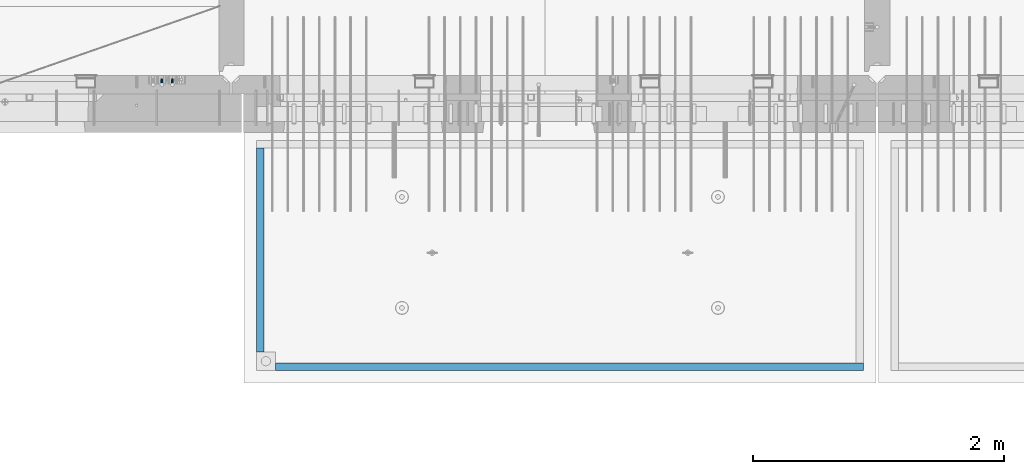
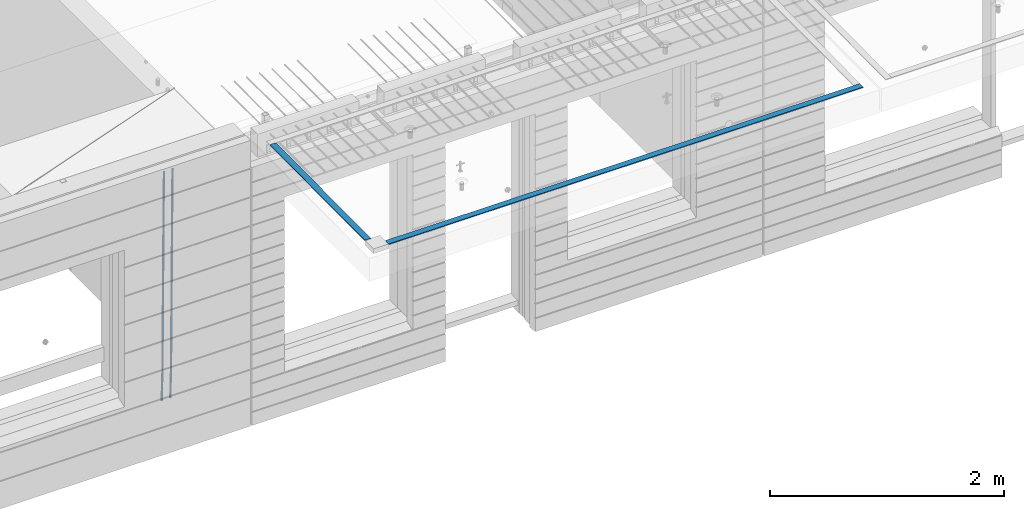
# One storey, part 90 of 341: 4 beams, 2 elements without a shape of their own.
"""IFC2X3 building model written with IfcOpenShell, lengths in millimetres."""

from ifc_helpers import new_model, si_unit, frame, origin_with_axes, place, context, subcontext, project, spatial, faceted_brep, material, type_object, element, aggregate, save


model = new_model("IFC2X3")

# Units and contexts
model_context = context("Model", 3, precision=1e-05, world=origin_with_axes())
body_context = subcontext(model_context, "Body", "Model", "MODEL_VIEW")
ifc_project = project(units=[si_unit("LENGTHUNIT", "METRE", prefix="MILLI"), si_unit("AREAUNIT", "SQUARE_METRE"), si_unit("VOLUMEUNIT", "CUBIC_METRE"), si_unit("MASSUNIT", "GRAM", prefix="KILO"), si_unit("TIMEUNIT", "SECOND"), si_unit("PLANEANGLEUNIT", "RADIAN"), si_unit("SOLIDANGLEUNIT", "STERADIAN"), si_unit("THERMODYNAMICTEMPERATUREUNIT", "DEGREE_CELSIUS"), si_unit("LUMINOUSINTENSITYUNIT", "LUMEN")], contexts=[model_context])

# Site, building, storey
site_placement = place(None, origin_with_axes())
site = spatial("IfcSite", under=ifc_project, at=site_placement, CompositionType="ELEMENT")
building_placement = place(site_placement, origin_with_axes())
building = spatial("IfcBuilding", under=site, at=building_placement, CompositionType="ELEMENT")
storey_placement = place(building_placement, origin_with_axes())
storey = spatial("IfcBuildingStorey", under=building, at=storey_placement, Name="5", CompositionType="ELEMENT", Elevation=0.0)

# Assembly, beams
assembly_1_placement = place(storey_placement, origin_with_axes())
assembly_1 = element("IfcElementAssembly", 1, at=assembly_1_placement, inside=storey, AssemblyPlace="NOTDEFINED", PredefinedType="REINFORCEMENT_UNIT")
ifc_material_1 = material()
beam_type_1 = type_object("IfcBeamType", Name="D20", PredefinedType="NOTDEFINED")
beam_1_placement = place(assembly_1_placement, frame((16189.9999999961, 7965.00000227913, 93990.0), z_axis=(0.00020576299992186, -0.999642804629538, -0.0267249099901004), x_axis=(-4.30000201928125e-08, -0.0267249099948059, 0.999642825806181)))
beam_1 = element("IfcBeam", 2, at=beam_1_placement, type_object=beam_type_1, material=ifc_material_1, Name="JM20", ObjectType="D20", context=body_context, shape_type="Brep", body=[
    faceted_brep([(0.0, -10.0, 0.0), (-4.19531716033816e-08, -7.07106781186667, -7.07106781187031), (60.4266690400545, -7.0710677960451, -7.07106780570757), (60.4266690441291, -9.99999998418934, 6.15546014159918e-09), (0.0, 0.0, -10.0), (60.426669036824, 1.58106558956206e-08, -9.99999999384454), (4.196772351861e-08, 7.07106781186303, -7.07106781186667), (60.4266690363438, 7.07106782768096, -7.07106780570757), (0.0, 10.0, 0.0), (60.4266690388904, 10.0000000158179, 6.15182216279209e-09), (4.196772351861e-08, 7.07106781185939, 7.07106781185939), (60.4266690429649, 7.07106782768096, 7.07106781802577), (0.0, 0.0, 10.0), (60.4266690461809, 1.58179318532348e-08, 10.0000000061555), (-4.19531716033816e-08, -7.07106781187031, 7.07106781185939), (60.4266690466611, -7.07106779605238, 7.07106781802213), (61.0378400410118, -7.07106779588503, -7.07106780564936), (60.991799419251, -9.99999998403655, 6.21366780251265e-09), (61.0569027789461, 1.5985278878361e-08, -9.99999999378269), (61.0378209396877, 7.07106782784831, -7.07106780564936), (60.9917724058905, 10.0000000159635, 6.21366780251265e-09), (60.9457317841297, 7.07106782781193, 7.0710678180767), (60.9266690461809, 1.59488990902901e-08, 10.0000000062028), (60.9457508854539, -7.07106779591413, 7.0710678180767), (61.6489592143771, -7.07106614513759, -7.06310863441468), (61.5568818710308, -9.9999984576425, 0.00735959856683621), (61.6870830769039, 1.71821739058942e-06, -9.99179257185824), (61.6489210170112, 7.07106947854481, -7.06310888312146), (61.556827851804, 10.0000015422847, 0.00735924683976918), (61.4647505084577, 7.07106922979438, 7.07782747982128), (61.4266266459163, 1.36643211590126e-06, 10.0065114172685), (61.464788705809, -7.07106639389531, 7.07782772852806), (176.543135720174, -7.07075579406956, -5.56673531796696), (176.451058376813, -9.99968810657447, 1.50373291501455), (176.581259582701, 0.000312069292704109, -8.49541925541052), (176.543097522794, 7.07137982961285, -5.56673556667374), (176.451004357587, 10.00031189336, 1.50373256329476), (176.35892701424, 7.07137958085514, 8.57420079627263), (176.320803151699, 0.000311717507429421, 11.5028847337162), (176.358965211621, -7.07075604281999, 8.57420104497578), (177.098753836006, -7.07075429323595, -5.55949898843028), (176.98362511232, -9.99968666800123, 1.510669025065), (177.146421932586, 0.000313595905026887, -8.48805862247536), (177.098706077581, 7.07138133041735, -5.55949936166144), (176.983557571715, 10.0003133318824, 1.51066849724157), (176.868428848029, 7.07138095712435, 8.58083651073321), (176.820760751449, 0.000313067976094317, 11.5093961447819), (176.868476606425, -7.07075466652896, 8.58083688396073), (177.654312950661, -7.07075204110879, -5.54863964998367), (177.516135294456, -9.99968450931192, 1.52107783331303), (177.711524267797, 0.000315886711177882, -8.47701274570863), (177.654255632195, 7.07138358250813, -5.54864021007961), (177.516054233929, 10.0003154905207, 1.5210770412159), (177.377876577739, 7.0713830223176, 8.59079452451624), (177.320665260588, 0.000315094497636892, 11.5191676202448), (177.377933896176, -7.07075260129932, 8.59079508461218), (299.436796249574, -7.07025836271714, -3.1681962331204), (299.298618593355, -9.99919083092027, 3.90152125031091), (299.494007566798, 0.000809565110102994, -6.09656932889993), (299.436738931283, 7.07187726089978, -3.16819679320906), (299.298537533061, 10.0008091689197, 3.90152045822106), (299.160359876842, 7.07187670072017, 10.9712379416487), (299.103148559603, 0.000808772889286047, 13.8996110374392), (299.160417195119, -7.07025892290039, 10.9712385017483), (299.98743051647, -7.07025613056248, -3.15743315966392), (299.971788958996, -9.99918809853989, 3.91467979818117), (299.993912075952, 0.000811591617093654, -6.08679785393178), (299.987423933868, 7.07187949325817, -3.1574327280432), (299.971753863239, 10.0008119014747, 3.91467990454839), (299.95611230444, 7.07187992653053, 10.9867922621015), (299.949630744944, 0.000812204350950196, 13.9161569563694), (299.956118887014, -7.07025569729012, 10.9867918304735), (300.538107039494, -7.07025785017686, -3.16575821840888), (300.644985195438, -9.99919020432935, 3.90450175465594), (300.493854948218, 0.000810030429420294, -6.09435592770024), (300.538151196495, 7.071877773491, -3.16575855385963), (300.645047642858, 10.0008097955724, 3.90450128024895), (300.751925798773, 7.07187744142357, 10.9747612533101), (300.796177890064, 0.000809560813650023, 13.9033589625978), (300.751881641787, -7.07025818224065, 10.9747615887682), (2293.36490490142, -7.07648090940347, -33.2930642912361), (2293.47178305736, -10.0054132635523, -26.2228043181785), (2293.32065281013, -0.00541302880083094, -36.2216620005347), (2293.36494905842, 7.06565471425711, -33.2930646266868), (2293.47184550477, 9.99458673634581, -26.2228047925819), (2293.57872366071, 7.06565438219332, -19.1525448195243), (2293.62297575199, -0.00541349841296324, -16.2239471102366), (2293.57867950371, -7.0764812414709, -19.1525444840736), (2294.0658245362, -7.07648309818615, -33.3036607065333), (2294.05312277409, -10.0054150789219, -26.2315929392535), (2294.10928714235, -0.00541549149056664, -36.2335844756526), (2294.15805078732, 7.06565223761572, -33.3050546393533), (2294.18355038921, 9.99458451388637, -26.2335642579346), (2294.17084862708, 7.06565253314329, -19.1614964906439), (2294.12738602093, -0.00541507354500936, -16.2315727215355), (2294.07862237596, -7.07648280265857, -19.1601025578348), (2294.76670261032, -7.08562269121467, -33.294332712383), (2294.63442802057, -10.0129954178956, -26.2238563411993), (2294.89787471293, -0.0156988342423574, -36.2230891548279), (2294.95110548967, 7.05531064255774, -33.2944998654275), (2294.89521307347, 9.98530428734011, -26.2240927312887), (2294.76293848372, 7.0579315606592, -19.1536163601049), (2294.63176638114, -0.0119922963167483, -16.2248599176673), (2294.57853560438, -7.08300177311321, -19.1534492070678), (2316.52657204497, -7.36937582653991, -33.0047303660212), (2316.39429745522, -10.2967485532172, -25.9342539948302), (2316.65774414754, -0.299451969567599, -35.9334868084661), (2316.7109749243, 6.7715575072325, -33.0048975190657), (2316.65508250811, 9.70155115201487, -25.9344903849269), (2316.52280791836, 6.7741784253376, -18.8640140137468), (2316.39163581574, -0.295745431634714, -15.9352575713092), (2316.33840503903, -7.36675490843481, -18.863846860706), (2317.16202064224, -7.37766220584308, -32.9962731735213), (2317.05438744847, -10.3053562613532, -25.9254688497131), (2317.23607125619, -0.306993473008333, -35.925789846493), (2317.23316144495, 6.76474808850253, -32.9979477328052), (2317.15499573652, 9.6950321815566, -25.9278370341635), (2317.04736254275, 6.7673381260538, -18.8570327103698), (2316.97331192881, -0.303330606784584, -15.9275160373909), (2316.97622174003, -7.37507216829545, -18.8553581510787), (2317.79752306276, -7.37578610372293, -32.9880110666527), (2317.71453320107, -10.3033876998124, -25.9168792378296), (2317.81444760226, -0.305295583297266, -35.918287695793), (2317.75539265381, 6.76628640723357, -32.9911928173897), (2317.65495180529, 9.69652304524061, -25.9213789128698), (2317.5719619436, 6.76892144914746, -18.8502470840467), (2317.55503740412, -0.301569071270933, -15.9199704549137), (2317.61409235255, -7.3731510618054, -18.847065333317), (2417.8183084176, -7.07752398473531, -31.6906369377139), (2417.73531855589, -10.0051255808248, -24.6195051088798), (2417.83523295709, -0.007033464313281, -34.6209135668432), (2417.77617800863, 7.06454852621755, -31.6938186884508), (2417.67573716014, 9.99478516423187, -24.6240047839383), (2417.59274729842, 7.06718356813872, -17.5528729551006), (2417.57582275895, -0.00330695228694822, -14.6225963259749), (2417.6348777074, -7.07488894281778, -17.5496912043673)], [[[0, 1, 2, 3]], [[1, 4, 5, 2]], [[4, 6, 7, 5]], [[6, 8, 9, 7]], [[8, 10, 11, 9]], [[10, 12, 13, 11]], [[12, 14, 15, 13]], [[14, 0, 3, 15]], [[14, 12, 10, 8, 6, 4, 1, 0]], [[3, 2, 16, 17]], [[2, 5, 18, 16]], [[5, 7, 19, 18]], [[7, 9, 20, 19]], [[9, 11, 21, 20]], [[11, 13, 22, 21]], [[13, 15, 23, 22]], [[15, 3, 17, 23]], [[17, 16, 24, 25]], [[16, 18, 26, 24]], [[18, 19, 27, 26]], [[19, 20, 28, 27]], [[20, 21, 29, 28]], [[21, 22, 30, 29]], [[22, 23, 31, 30]], [[23, 17, 25, 31]], [[25, 24, 32, 33]], [[24, 26, 34, 32]], [[26, 27, 35, 34]], [[27, 28, 36, 35]], [[28, 29, 37, 36]], [[29, 30, 38, 37]], [[30, 31, 39, 38]], [[31, 25, 33, 39]], [[33, 32, 40, 41]], [[32, 34, 42, 40]], [[34, 35, 43, 42]], [[35, 36, 44, 43]], [[36, 37, 45, 44]], [[37, 38, 46, 45]], [[38, 39, 47, 46]], [[39, 33, 41, 47]], [[41, 40, 48, 49]], [[40, 42, 50, 48]], [[42, 43, 51, 50]], [[43, 44, 52, 51]], [[44, 45, 53, 52]], [[45, 46, 54, 53]], [[46, 47, 55, 54]], [[47, 41, 49, 55]], [[49, 48, 56, 57]], [[48, 50, 58, 56]], [[50, 51, 59, 58]], [[51, 52, 60, 59]], [[52, 53, 61, 60]], [[53, 54, 62, 61]], [[54, 55, 63, 62]], [[55, 49, 57, 63]], [[57, 56, 64, 65]], [[56, 58, 66, 64]], [[58, 59, 67, 66]], [[59, 60, 68, 67]], [[60, 61, 69, 68]], [[61, 62, 70, 69]], [[62, 63, 71, 70]], [[63, 57, 65, 71]], [[65, 64, 72, 73]], [[64, 66, 74, 72]], [[66, 67, 75, 74]], [[67, 68, 76, 75]], [[68, 69, 77, 76]], [[69, 70, 78, 77]], [[70, 71, 79, 78]], [[71, 65, 73, 79]], [[73, 72, 80, 81]], [[72, 74, 82, 80]], [[74, 75, 83, 82]], [[75, 76, 84, 83]], [[76, 77, 85, 84]], [[77, 78, 86, 85]], [[78, 79, 87, 86]], [[79, 73, 81, 87]], [[81, 80, 88, 89]], [[80, 82, 90, 88]], [[82, 83, 91, 90]], [[83, 84, 92, 91]], [[84, 85, 93, 92]], [[85, 86, 94, 93]], [[86, 87, 95, 94]], [[87, 81, 89, 95]], [[89, 88, 96, 97]], [[88, 90, 98, 96]], [[90, 91, 99, 98]], [[91, 92, 100, 99]], [[92, 93, 101, 100]], [[93, 94, 102, 101]], [[94, 95, 103, 102]], [[95, 89, 97, 103]], [[97, 96, 104, 105]], [[96, 98, 106, 104]], [[98, 99, 107, 106]], [[99, 100, 108, 107]], [[100, 101, 109, 108]], [[101, 102, 110, 109]], [[102, 103, 111, 110]], [[103, 97, 105, 111]], [[105, 104, 112, 113]], [[104, 106, 114, 112]], [[106, 107, 115, 114]], [[107, 108, 116, 115]], [[108, 109, 117, 116]], [[109, 110, 118, 117]], [[110, 111, 119, 118]], [[111, 105, 113, 119]], [[113, 112, 120, 121]], [[112, 114, 122, 120]], [[114, 115, 123, 122]], [[115, 116, 124, 123]], [[116, 117, 125, 124]], [[117, 118, 126, 125]], [[118, 119, 127, 126]], [[119, 113, 121, 127]], [[121, 120, 128, 129]], [[120, 122, 130, 128]], [[122, 123, 131, 130]], [[123, 124, 132, 131]], [[124, 125, 133, 132]], [[125, 126, 134, 133]], [[126, 127, 135, 134]], [[127, 121, 129, 135]], [[130, 131, 132, 133, 134, 135, 129, 128]]]),
])
beam_2_placement = place(assembly_1_placement, frame((16104.9999999961, 7965.00000227913, 93990.0), z_axis=(0.00020576299992186, -0.999642804629538, -0.0267249099901004), x_axis=(-4.30000201928125e-08, -0.0267249099948059, 0.999642825806181)))
beam_2 = element("IfcBeam", 3, at=beam_2_placement, type_object=beam_type_1, material=ifc_material_1, Name="JM20", ObjectType="D20", context=body_context, shape_type="Brep", body=[
    faceted_brep([(0.0, -10.0, 0.0), (-4.19531716033816e-08, -7.07106781186667, -7.07106781187031), (60.4266690400545, -7.0710677960451, -7.07106780570757), (60.4266690441291, -9.99999998418934, 6.15546014159918e-09), (0.0, 0.0, -10.0), (60.426669036824, 1.58106558956206e-08, -9.99999999384454), (4.196772351861e-08, 7.07106781186303, -7.07106781186667), (60.4266690363438, 7.07106782768096, -7.07106780570757), (0.0, 10.0, 0.0), (60.4266690388904, 10.0000000158179, 6.15182216279209e-09), (4.196772351861e-08, 7.07106781185939, 7.07106781185939), (60.4266690429649, 7.07106782768096, 7.07106781802577), (0.0, 0.0, 10.0), (60.4266690461809, 1.58179318532348e-08, 10.0000000061555), (-4.19531716033816e-08, -7.07106781187031, 7.07106781185939), (60.4266690466611, -7.07106779605238, 7.07106781802213), (61.0378400410118, -7.07106779588503, -7.07106780564936), (60.991799419251, -9.99999998403655, 6.21366780251265e-09), (61.0569027789461, 1.5985278878361e-08, -9.99999999378269), (61.0378209396877, 7.07106782784831, -7.07106780564936), (60.9917724058905, 10.0000000159635, 6.21366780251265e-09), (60.9457317841297, 7.07106782781193, 7.0710678180767), (60.9266690461809, 1.59488990902901e-08, 10.0000000062028), (60.9457508854539, -7.07106779591413, 7.0710678180767), (61.6489592143771, -7.07106614513759, -7.06310863441468), (61.5568818710308, -9.9999984576425, 0.00735959856683621), (61.6870830769039, 1.71821739058942e-06, -9.99179257185824), (61.6489210170112, 7.07106947854481, -7.06310888312146), (61.556827851804, 10.0000015422847, 0.00735924683976918), (61.4647505084577, 7.07106922979438, 7.07782747982128), (61.4266266459163, 1.36643211590126e-06, 10.0065114172685), (61.464788705809, -7.07106639389531, 7.07782772852806), (176.543135720174, -7.07075579406956, -5.56673531796696), (176.451058376813, -9.99968810657447, 1.50373291501455), (176.581259582701, 0.000312069292704109, -8.49541925541052), (176.543097522794, 7.07137982961285, -5.56673556667374), (176.451004357587, 10.00031189336, 1.50373256329476), (176.35892701424, 7.07137958085514, 8.57420079627263), (176.320803151699, 0.000311717507429421, 11.5028847337162), (176.358965211621, -7.07075604281999, 8.57420104497578), (177.098753836006, -7.07075429323595, -5.55949898843028), (176.98362511232, -9.99968666800123, 1.510669025065), (177.146421932586, 0.000313595905026887, -8.48805862247536), (177.098706077581, 7.07138133041735, -5.55949936166144), (176.983557571715, 10.0003133318824, 1.51066849724157), (176.868428848029, 7.07138095712435, 8.58083651073321), (176.820760751449, 0.000313067976094317, 11.5093961447819), (176.868476606425, -7.07075466652896, 8.58083688396073), (177.654312950661, -7.07075204110879, -5.54863964998367), (177.516135294456, -9.99968450931192, 1.52107783331303), (177.711524267797, 0.000315886711177882, -8.47701274570863), (177.654255632195, 7.07138358250813, -5.54864021007961), (177.516054233929, 10.0003154905207, 1.5210770412159), (177.377876577739, 7.0713830223176, 8.59079452451624), (177.320665260588, 0.000315094497636892, 11.5191676202448), (177.377933896176, -7.07075260129932, 8.59079508461218), (299.436796249574, -7.07025836271714, -3.1681962331204), (299.298618593355, -9.99919083092027, 3.90152125031091), (299.494007566798, 0.000809565110102994, -6.09656932889993), (299.436738931283, 7.07187726089978, -3.16819679320906), (299.298537533061, 10.0008091689197, 3.90152045822106), (299.160359876842, 7.07187670072017, 10.9712379416487), (299.103148559603, 0.000808772889286047, 13.8996110374392), (299.160417195119, -7.07025892290039, 10.9712385017483), (299.98743051647, -7.07025613056248, -3.15743315966392), (299.971788958996, -9.99918809853989, 3.91467979818117), (299.993912075952, 0.000811591617093654, -6.08679785393178), (299.987423933868, 7.07187949325817, -3.1574327280432), (299.971753863239, 10.0008119014747, 3.91467990454839), (299.95611230444, 7.07187992653053, 10.9867922621015), (299.949630744944, 0.000812204350950196, 13.9161569563694), (299.956118887014, -7.07025569729012, 10.9867918304735), (300.538107039494, -7.07025785017686, -3.16575821840888), (300.644985195438, -9.99919020432935, 3.90450175465594), (300.493854948218, 0.000810030429420294, -6.09435592770024), (300.538151196495, 7.071877773491, -3.16575855385963), (300.645047642858, 10.0008097955724, 3.90450128024895), (300.751925798773, 7.07187744142357, 10.9747612533101), (300.796177890064, 0.000809560813650023, 13.9033589625978), (300.751881641787, -7.07025818224065, 10.9747615887682), (2293.36490490142, -7.07648090940347, -33.2930642912361), (2293.47178305736, -10.0054132635523, -26.2228043181785), (2293.32065281013, -0.00541302880083094, -36.2216620005347), (2293.36494905842, 7.06565471425711, -33.2930646266868), (2293.47184550477, 9.99458673634581, -26.2228047925819), (2293.57872366071, 7.06565438219332, -19.1525448195243), (2293.62297575199, -0.00541349841296324, -16.2239471102366), (2293.57867950371, -7.0764812414709, -19.1525444840736), (2294.0658245362, -7.07648309818615, -33.3036607065333), (2294.05312277409, -10.0054150789219, -26.2315929392535), (2294.10928714235, -0.00541549149056664, -36.2335844756526), (2294.15805078732, 7.06565223761572, -33.3050546393533), (2294.18355038921, 9.99458451388637, -26.2335642579346), (2294.17084862708, 7.06565253314329, -19.1614964906439), (2294.12738602093, -0.00541507354500936, -16.2315727215355), (2294.07862237596, -7.07648280265857, -19.1601025578348), (2294.76670261032, -7.08562269121467, -33.294332712383), (2294.63442802057, -10.0129954178956, -26.2238563411993), (2294.89787471293, -0.0156988342423574, -36.2230891548279), (2294.95110548967, 7.05531064255774, -33.2944998654275), (2294.89521307347, 9.98530428734011, -26.2240927312887), (2294.76293848372, 7.0579315606592, -19.1536163601049), (2294.63176638114, -0.0119922963167483, -16.2248599176673), (2294.57853560438, -7.08300177311321, -19.1534492070678), (2316.52657204497, -7.36937582653991, -33.0047303660212), (2316.39429745522, -10.2967485532172, -25.9342539948302), (2316.65774414754, -0.299451969567599, -35.9334868084661), (2316.7109749243, 6.7715575072325, -33.0048975190657), (2316.65508250811, 9.70155115201487, -25.9344903849269), (2316.52280791836, 6.7741784253376, -18.8640140137468), (2316.39163581574, -0.295745431634714, -15.9352575713092), (2316.33840503903, -7.36675490843481, -18.863846860706), (2317.16202064224, -7.37766220584308, -32.9962731735213), (2317.05438744847, -10.3053562613532, -25.9254688497131), (2317.23607125619, -0.306993473008333, -35.925789846493), (2317.23316144495, 6.76474808850253, -32.9979477328052), (2317.15499573652, 9.6950321815566, -25.9278370341635), (2317.04736254275, 6.7673381260538, -18.8570327103698), (2316.97331192881, -0.303330606784584, -15.9275160373909), (2316.97622174003, -7.37507216829545, -18.8553581510787), (2317.79752306276, -7.37578610372293, -32.9880110666527), (2317.71453320107, -10.3033876998124, -25.9168792378296), (2317.81444760226, -0.305295583297266, -35.918287695793), (2317.75539265381, 6.76628640723357, -32.9911928173897), (2317.65495180529, 9.69652304524061, -25.9213789128698), (2317.5719619436, 6.76892144914746, -18.8502470840467), (2317.55503740412, -0.301569071270933, -15.9199704549137), (2317.61409235255, -7.3731510618054, -18.847065333317), (2417.8183084176, -7.07752398473531, -31.6906369377139), (2417.73531855589, -10.0051255808248, -24.6195051088798), (2417.83523295709, -0.007033464313281, -34.6209135668432), (2417.77617800863, 7.06454852621755, -31.6938186884508), (2417.67573716014, 9.99478516423187, -24.6240047839383), (2417.59274729842, 7.06718356813872, -17.5528729551006), (2417.57582275895, -0.00330695228694822, -14.6225963259749), (2417.6348777074, -7.07488894281778, -17.5496912043673)], [[[0, 1, 2, 3]], [[1, 4, 5, 2]], [[4, 6, 7, 5]], [[6, 8, 9, 7]], [[8, 10, 11, 9]], [[10, 12, 13, 11]], [[12, 14, 15, 13]], [[14, 0, 3, 15]], [[14, 12, 10, 8, 6, 4, 1, 0]], [[3, 2, 16, 17]], [[2, 5, 18, 16]], [[5, 7, 19, 18]], [[7, 9, 20, 19]], [[9, 11, 21, 20]], [[11, 13, 22, 21]], [[13, 15, 23, 22]], [[15, 3, 17, 23]], [[17, 16, 24, 25]], [[16, 18, 26, 24]], [[18, 19, 27, 26]], [[19, 20, 28, 27]], [[20, 21, 29, 28]], [[21, 22, 30, 29]], [[22, 23, 31, 30]], [[23, 17, 25, 31]], [[25, 24, 32, 33]], [[24, 26, 34, 32]], [[26, 27, 35, 34]], [[27, 28, 36, 35]], [[28, 29, 37, 36]], [[29, 30, 38, 37]], [[30, 31, 39, 38]], [[31, 25, 33, 39]], [[33, 32, 40, 41]], [[32, 34, 42, 40]], [[34, 35, 43, 42]], [[35, 36, 44, 43]], [[36, 37, 45, 44]], [[37, 38, 46, 45]], [[38, 39, 47, 46]], [[39, 33, 41, 47]], [[41, 40, 48, 49]], [[40, 42, 50, 48]], [[42, 43, 51, 50]], [[43, 44, 52, 51]], [[44, 45, 53, 52]], [[45, 46, 54, 53]], [[46, 47, 55, 54]], [[47, 41, 49, 55]], [[49, 48, 56, 57]], [[48, 50, 58, 56]], [[50, 51, 59, 58]], [[51, 52, 60, 59]], [[52, 53, 61, 60]], [[53, 54, 62, 61]], [[54, 55, 63, 62]], [[55, 49, 57, 63]], [[57, 56, 64, 65]], [[56, 58, 66, 64]], [[58, 59, 67, 66]], [[59, 60, 68, 67]], [[60, 61, 69, 68]], [[61, 62, 70, 69]], [[62, 63, 71, 70]], [[63, 57, 65, 71]], [[65, 64, 72, 73]], [[64, 66, 74, 72]], [[66, 67, 75, 74]], [[67, 68, 76, 75]], [[68, 69, 77, 76]], [[69, 70, 78, 77]], [[70, 71, 79, 78]], [[71, 65, 73, 79]], [[73, 72, 80, 81]], [[72, 74, 82, 80]], [[74, 75, 83, 82]], [[75, 76, 84, 83]], [[76, 77, 85, 84]], [[77, 78, 86, 85]], [[78, 79, 87, 86]], [[79, 73, 81, 87]], [[81, 80, 88, 89]], [[80, 82, 90, 88]], [[82, 83, 91, 90]], [[83, 84, 92, 91]], [[84, 85, 93, 92]], [[85, 86, 94, 93]], [[86, 87, 95, 94]], [[87, 81, 89, 95]], [[89, 88, 96, 97]], [[88, 90, 98, 96]], [[90, 91, 99, 98]], [[91, 92, 100, 99]], [[92, 93, 101, 100]], [[93, 94, 102, 101]], [[94, 95, 103, 102]], [[95, 89, 97, 103]], [[97, 96, 104, 105]], [[96, 98, 106, 104]], [[98, 99, 107, 106]], [[99, 100, 108, 107]], [[100, 101, 109, 108]], [[101, 102, 110, 109]], [[102, 103, 111, 110]], [[103, 97, 105, 111]], [[105, 104, 112, 113]], [[104, 106, 114, 112]], [[106, 107, 115, 114]], [[107, 108, 116, 115]], [[108, 109, 117, 116]], [[109, 110, 118, 117]], [[110, 111, 119, 118]], [[111, 105, 113, 119]], [[113, 112, 120, 121]], [[112, 114, 122, 120]], [[114, 115, 123, 122]], [[115, 116, 124, 123]], [[116, 117, 125, 124]], [[117, 118, 126, 125]], [[118, 119, 127, 126]], [[119, 113, 121, 127]], [[121, 120, 128, 129]], [[120, 122, 130, 128]], [[122, 123, 131, 130]], [[123, 124, 132, 131]], [[124, 125, 133, 132]], [[125, 126, 134, 133]], [[126, 127, 135, 134]], [[127, 121, 129, 135]], [[130, 131, 132, 133, 134, 135, 129, 128]]]),
])
aggregate(assembly_1, [beam_1, beam_2])

assembly_2_placement = place(storey_placement, origin_with_axes())
assembly_2 = element("IfcElementAssembly", 4, at=assembly_2_placement, inside=storey, AssemblyPlace="NOTDEFINED", PredefinedType="REINFORCEMENT_UNIT")
ifc_material_2 = material(Name="CONCRETE/Concrete_Undefined")
beam_type_2 = type_object("IfcBeamType", PredefinedType="NOTDEFINED")
beam_3_placement = place(assembly_2_placement, frame((17009.999743725, 5674.95858499901, 96709.8102146119), z_axis=(0.000380798000187366, 3.00000010760189e-09, 0.999999927496439), x_axis=(0.99999992747398, 6.70200000315108e-06, -0.000380798000181631)))
beam_3 = element("IfcBeam", 5, at=beam_3_placement, type_object=beam_type_2, material=ifc_material_2, context=body_context, shape_type="Brep", body=[
    faceted_brep([(2.5465851649642e-11, 29.9999999999982, -4.99999999998545), (-2.91038304567337e-11, 29.9999999999982, 5.0), (4690.00295566467, 30.0, 5.00000000001455), (4690.00295566467, 30.0000000000009, -4.99999999998545), (-2.5465851649642e-11, -30.0000000000018, 5.0), (4690.00295566467, -30.0, 5.00000000001455), (2.72848410531878e-11, -30.0000000000018, -4.99999999998545), (4690.00295566467, -30.0, -5.0)], [[[0, 1, 2, 3]], [[1, 4, 5, 2]], [[4, 6, 7, 5]], [[6, 0, 3, 7]], [[5, 7, 3, 2]], [[6, 4, 1, 0]]]),
])
beam_4_placement = place(assembly_2_placement, frame((16889.9913896902, 7420.06323332097, 96723.6636421195), z_axis=(3.06000001756964e-07, -0.00861454800079991, 0.9999628940929), x_axis=(3.55420000171828e-05, -0.999962893461279, -0.00861454800397781)))
beam_4 = element("IfcBeam", 6, at=beam_4_placement, type_object=beam_type_2, material=ifc_material_2, context=body_context, shape_type="Brep", body=[
    faceted_brep([(2.5465851649642e-11, 29.9999999999982, -4.99999999998545), (-2.91038304567337e-11, 29.9999999999982, 5.0), (1625.15608040099, 30.0000000000073, 5.0), (1625.15608040101, 30.0000000000036, -4.99999999998545), (-2.5465851649642e-11, -30.0000000000018, 5.0), (1625.15608040099, -29.9999999999964, 5.0), (2.72848410531878e-11, -30.0000000000018, -4.99999999998545), (1625.15608040101, -29.9999999999964, -4.99999999998545)], [[[0, 1, 2, 3]], [[1, 4, 5, 2]], [[4, 6, 7, 5]], [[6, 0, 3, 7]], [[5, 7, 3, 2]], [[6, 4, 1, 0]]]),
])
aggregate(assembly_2, [beam_3, beam_4])

save(model, "model.ifc")
